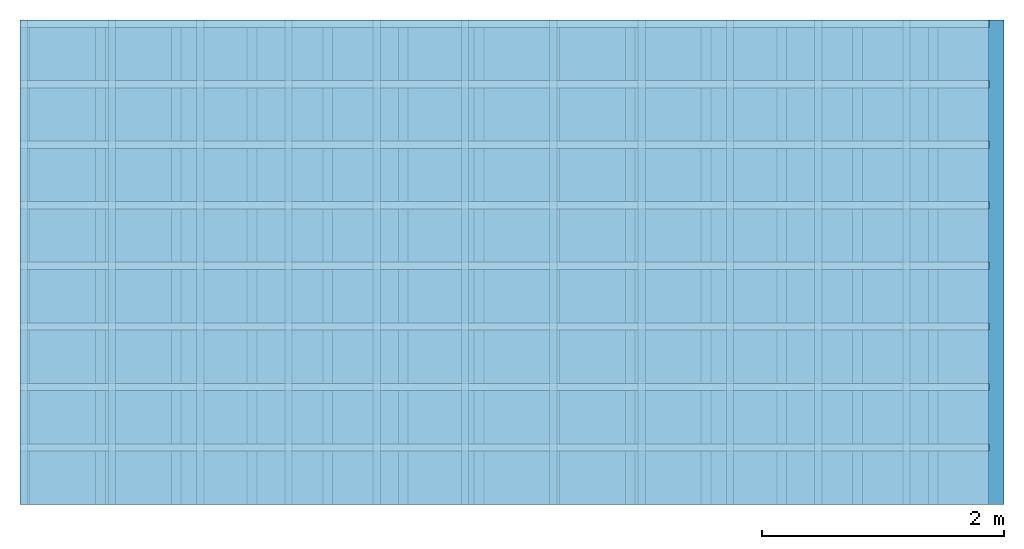
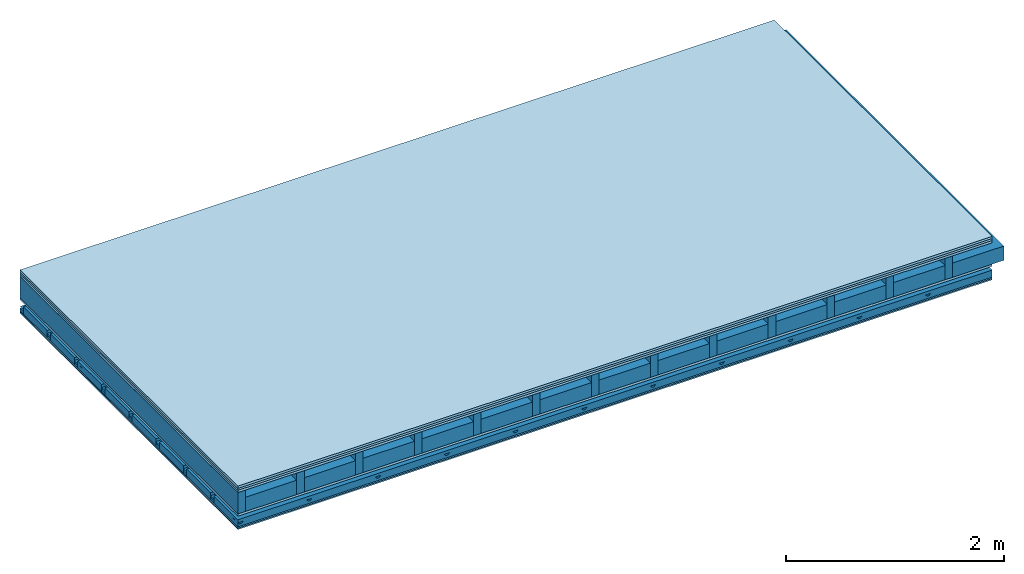
# One storey: 6 plates, 5 members, 1 element without a shape of its own.
"""IFC4 building model written with IfcOpenShell, lengths in metres."""

from ifc_helpers import new_model, si_unit, derived_unit, direction, frame, frame_2d, origin, origin_with_axes, place, context, project, spatial, polyline, rectangle, outline, extrude, material, layer, layer_set, type_object, element, aggregate, save


model = new_model("IFC4")

# Units and contexts
plan_context = context("Plan", 3, precision=1e-05, world=origin(), true_north=direction((0.0, 1.0)))
model_context = context("Model", 3, precision=1e-05, world=origin(), true_north=direction((0.0, 1.0)))
ifc_project = project(units=[si_unit("LENGTHUNIT", "METRE"), derived_unit("SOUNDPRESSUREUNIT", [(si_unit("PRESSUREUNIT", "PASCAL", prefix="MICRO"), 0)]), si_unit("ENERGYUNIT", "JOULE", prefix="MEGA"), si_unit("MASSUNIT", "GRAM", prefix="KILO"), derived_unit("THERMALTRANSMITTANCEUNIT", [(si_unit("POWERUNIT", "WATT"), 1), (si_unit("AREAUNIT", "SQUARE_METRE"), -1), (si_unit("THERMODYNAMICTEMPERATUREUNIT", "KELVIN"), -1)]), derived_unit("AREADENSITYUNIT", [(si_unit("MASSUNIT", "GRAM", prefix="KILO"), 1), (si_unit("AREAUNIT", "SQUARE_METRE"), -1)]), derived_unit("USERDEFINED", [(si_unit("ENERGYUNIT", "JOULE", prefix="MEGA"), 1), (si_unit("AREAUNIT", "SQUARE_METRE"), -1)])], contexts=[plan_context, model_context])

# Site, building, storey
site = spatial("IfcSite", under=ifc_project)
building_placement = place(None, origin())
building = spatial("IfcBuilding", under=site, at=building_placement)
storey_placement = place(building_placement, origin())
storey = spatial("IfcBuildingStorey", under=building, at=storey_placement)

# Slab, members, plates
ifc_material_1 = material(Name="Floor heating system Therm38 longitudinal", Category="03.007")
ifc_layer_1 = layer(ifc_material_1, 0.025, Name="On-material")
ifc_material_2 = material(Category="10.009")
ifc_layer_2 = layer(ifc_material_2, 0.022, Name="Impact sound insulation")
ifc_material_3 = material(Category="07.001")
ifc_layer_3 = layer(ifc_material_3, 0.025, Name="Sub-floor")
ifc_material_4 = material(Name="Rigid, of the art")
ifc_layer_4 = layer(ifc_material_4, 0.0, Name="Bond")
ifc_layer_5 = layer(None, 0.24, Name="Supporting structure")
ifc_layer_6 = layer(ifc_material_4, 0.0, Name="Bond")
ifc_layer_7 = layer(ifc_material_3, 0.025, Name="Lower layer 1")
ifc_layer_8 = layer(None, 0.093, Name="Coupling")
ifc_layer_9 = layer(None, 0.027, Name="Battens / profiles")
ifc_material_5 = material(Category="03.007")
ifc_layer_10 = layer(ifc_material_5, 0.015, Name="Ceiling covering 1st layer")
ifc_layer_11 = layer(ifc_material_5, 0.015, Name="Ceiling covering layer 2")
ifc_material_6 = material(Name="Glued joints")
ifc_layer_12 = layer(ifc_material_6, 0.0, Name="Surface / treatment")
ifc_layer_set = layer_set([ifc_layer_1, ifc_layer_2, ifc_layer_3, ifc_layer_4, ifc_layer_5, ifc_layer_6, ifc_layer_7, ifc_layer_8, ifc_layer_9, ifc_layer_10, ifc_layer_11, ifc_layer_12])
slab_type = type_object("IfcSlabType", Name="A0357", PredefinedType="NOTDEFINED", material=ifc_layer_set)
slab_placement = place(None, frame((0.0, 0.0, 0.0), z_axis=(0.0, 0.0, -1.0), x_axis=(1.0, 0.0, 0.0)))
slab = element("IfcSlab", 1, at=slab_placement, inside=storey, type_object=slab_type, material=ifc_layer_set, Name="Slab #1")
ifc_material_7 = material()
member_1_placement = place(slab_placement, origin())
member_1 = element("IfcMember", 2, at=member_1_placement, material=ifc_material_7, Name="Supporting structure", context=plan_context, shape_type="SweptSolid", body=[
    extrude(rectangle(XDim=0.08, YDim=0.24, at=frame_2d((0.04, 0.12), x_axis=(1.0, 0.0))), frame((0.0, 4.0, 0.072), z_axis=(0.0, -1.0, 0.0), x_axis=(1.0, 0.0, 0.0)), (0.0, 0.0, 1.0), 4.0),
    extrude(rectangle(XDim=0.08, YDim=0.24, at=frame_2d((0.04, 0.12), x_axis=(1.0, 0.0))), frame((0.625, 4.0, 0.072), z_axis=(0.0, -1.0, 0.0), x_axis=(1.0, 0.0, 0.0)), (0.0, 0.0, 1.0), 4.0),
    extrude(rectangle(XDim=0.08, YDim=0.24, at=frame_2d((0.04, 0.12), x_axis=(1.0, 0.0))), frame((1.25, 4.0, 0.072), z_axis=(0.0, -1.0, 0.0), x_axis=(1.0, 0.0, 0.0)), (0.0, 0.0, 1.0), 4.0),
    extrude(rectangle(XDim=0.08, YDim=0.24, at=frame_2d((0.04, 0.12), x_axis=(1.0, 0.0))), frame((1.875, 4.0, 0.072), z_axis=(0.0, -1.0, 0.0), x_axis=(1.0, 0.0, 0.0)), (0.0, 0.0, 1.0), 4.0),
    extrude(rectangle(XDim=0.08, YDim=0.24, at=frame_2d((0.04, 0.12), x_axis=(1.0, 0.0))), frame((2.5, 4.0, 0.072), z_axis=(0.0, -1.0, 0.0), x_axis=(1.0, 0.0, 0.0)), (0.0, 0.0, 1.0), 4.0),
    extrude(rectangle(XDim=0.08, YDim=0.24, at=frame_2d((0.04, 0.12), x_axis=(1.0, 0.0))), frame((3.125, 4.0, 0.072), z_axis=(0.0, -1.0, 0.0), x_axis=(1.0, 0.0, 0.0)), (0.0, 0.0, 1.0), 4.0),
    extrude(rectangle(XDim=0.08, YDim=0.24, at=frame_2d((0.04, 0.12), x_axis=(1.0, 0.0))), frame((3.75, 4.0, 0.072), z_axis=(0.0, -1.0, 0.0), x_axis=(1.0, 0.0, 0.0)), (0.0, 0.0, 1.0), 4.0),
    extrude(rectangle(XDim=0.08, YDim=0.24, at=frame_2d((0.04, 0.12), x_axis=(1.0, 0.0))), frame((4.375, 4.0, 0.072), z_axis=(0.0, -1.0, 0.0), x_axis=(1.0, 0.0, 0.0)), (0.0, 0.0, 1.0), 4.0),
    extrude(rectangle(XDim=0.08, YDim=0.24, at=frame_2d((0.04, 0.12), x_axis=(1.0, 0.0))), frame((5.0, 4.0, 0.072), z_axis=(0.0, -1.0, 0.0), x_axis=(1.0, 0.0, 0.0)), (0.0, 0.0, 1.0), 4.0),
    extrude(rectangle(XDim=0.08, YDim=0.24, at=frame_2d((0.04, 0.12), x_axis=(1.0, 0.0))), frame((5.625, 4.0, 0.072), z_axis=(0.0, -1.0, 0.0), x_axis=(1.0, 0.0, 0.0)), (0.0, 0.0, 1.0), 4.0),
    extrude(rectangle(XDim=0.08, YDim=0.24, at=frame_2d((0.04, 0.12), x_axis=(1.0, 0.0))), frame((6.25, 4.0, 0.072), z_axis=(0.0, -1.0, 0.0), x_axis=(1.0, 0.0, 0.0)), (0.0, 0.0, 1.0), 4.0),
    extrude(rectangle(XDim=0.08, YDim=0.24, at=frame_2d((0.04, 0.12), x_axis=(1.0, 0.0))), frame((6.875, 4.0, 0.072), z_axis=(0.0, -1.0, 0.0), x_axis=(1.0, 0.0, 0.0)), (0.0, 0.0, 1.0), 4.0),
    extrude(rectangle(XDim=0.08, YDim=0.24, at=frame_2d((0.04, 0.12), x_axis=(1.0, 0.0))), frame((7.5, 4.0, 0.072), z_axis=(0.0, -1.0, 0.0), x_axis=(1.0, 0.0, 0.0)), (0.0, 0.0, 1.0), 4.0),
])
ifc_material_8 = material()
member_2_placement = place(slab_placement, origin())
member_2 = element("IfcMember", 3, at=member_2_placement, material=ifc_material_8, Name="Cavity", context=plan_context, shape_type="SweptSolid", body=[
    extrude(rectangle(XDim=0.545, YDim=0.16, at=frame_2d((0.2725, 0.08), x_axis=(1.0, 0.0))), frame((0.08, 4.0, 0.152), z_axis=(0.0, -1.0, 0.0), x_axis=(1.0, 0.0, 0.0)), (0.0, 0.0, 1.0), 4.0),
    extrude(rectangle(XDim=0.545, YDim=0.16, at=frame_2d((0.2725, 0.08), x_axis=(1.0, 0.0))), frame((0.705, 4.0, 0.152), z_axis=(0.0, -1.0, 0.0), x_axis=(1.0, 0.0, 0.0)), (0.0, 0.0, 1.0), 4.0),
    extrude(rectangle(XDim=0.545, YDim=0.16, at=frame_2d((0.2725, 0.08), x_axis=(1.0, 0.0))), frame((1.33, 4.0, 0.152), z_axis=(0.0, -1.0, 0.0), x_axis=(1.0, 0.0, 0.0)), (0.0, 0.0, 1.0), 4.0),
    extrude(rectangle(XDim=0.545, YDim=0.16, at=frame_2d((0.2725, 0.08), x_axis=(1.0, 0.0))), frame((1.955, 4.0, 0.152), z_axis=(0.0, -1.0, 0.0), x_axis=(1.0, 0.0, 0.0)), (0.0, 0.0, 1.0), 4.0),
    extrude(rectangle(XDim=0.545, YDim=0.16, at=frame_2d((0.2725, 0.08), x_axis=(1.0, 0.0))), frame((2.58, 4.0, 0.152), z_axis=(0.0, -1.0, 0.0), x_axis=(1.0, 0.0, 0.0)), (0.0, 0.0, 1.0), 4.0),
    extrude(rectangle(XDim=0.545, YDim=0.16, at=frame_2d((0.2725, 0.08), x_axis=(1.0, 0.0))), frame((3.205, 4.0, 0.152), z_axis=(0.0, -1.0, 0.0), x_axis=(1.0, 0.0, 0.0)), (0.0, 0.0, 1.0), 4.0),
    extrude(rectangle(XDim=0.545, YDim=0.16, at=frame_2d((0.2725, 0.08), x_axis=(1.0, 0.0))), frame((3.83, 4.0, 0.152), z_axis=(0.0, -1.0, 0.0), x_axis=(1.0, 0.0, 0.0)), (0.0, 0.0, 1.0), 4.0),
    extrude(rectangle(XDim=0.545, YDim=0.16, at=frame_2d((0.2725, 0.08), x_axis=(1.0, 0.0))), frame((4.455, 4.0, 0.152), z_axis=(0.0, -1.0, 0.0), x_axis=(1.0, 0.0, 0.0)), (0.0, 0.0, 1.0), 4.0),
    extrude(rectangle(XDim=0.545, YDim=0.16, at=frame_2d((0.2725, 0.08), x_axis=(1.0, 0.0))), frame((5.08, 4.0, 0.152), z_axis=(0.0, -1.0, 0.0), x_axis=(1.0, 0.0, 0.0)), (0.0, 0.0, 1.0), 4.0),
    extrude(rectangle(XDim=0.545, YDim=0.16, at=frame_2d((0.2725, 0.08), x_axis=(1.0, 0.0))), frame((5.705, 4.0, 0.152), z_axis=(0.0, -1.0, 0.0), x_axis=(1.0, 0.0, 0.0)), (0.0, 0.0, 1.0), 4.0),
    extrude(rectangle(XDim=0.545, YDim=0.16, at=frame_2d((0.2725, 0.08), x_axis=(1.0, 0.0))), frame((6.33, 4.0, 0.152), z_axis=(0.0, -1.0, 0.0), x_axis=(1.0, 0.0, 0.0)), (0.0, 0.0, 1.0), 4.0),
    extrude(rectangle(XDim=0.545, YDim=0.16, at=frame_2d((0.2725, 0.08), x_axis=(1.0, 0.0))), frame((6.955, 4.0, 0.152), z_axis=(0.0, -1.0, 0.0), x_axis=(1.0, 0.0, 0.0)), (0.0, 0.0, 1.0), 4.0),
    extrude(rectangle(XDim=0.545, YDim=0.16, at=frame_2d((0.2725, 0.08), x_axis=(1.0, 0.0))), frame((7.58, 4.0, 0.152), z_axis=(0.0, -1.0, 0.0), x_axis=(1.0, 0.0, 0.0)), (0.0, 0.0, 1.0), 4.0),
])
ifc_material_9 = material()
member_3_placement = place(slab_placement, origin())
member_3 = element("IfcMember", 4, at=member_3_placement, material=ifc_material_9, Name="Coupling", context=plan_context, shape_type="SweptSolid", body=[
    extrude(outline(polyline([(0.0, 0.0), (0.06, 0.0), (0.04, 0.02), (0.02, 0.02), (0.0, 0.0)])), frame((0.0, 4.0, 0.41), z_axis=(0.0, -1.0, 0.0), x_axis=(1.0, 0.0, 0.0)), (0.0, 0.0, 1.0), 4.0),
    extrude(outline(polyline([(0.0, 0.0), (0.06, 0.0), (0.04, 0.02), (0.02, 0.02), (0.0, 0.0)])), frame((0.729, 4.0, 0.41), z_axis=(0.0, -1.0, 0.0), x_axis=(1.0, 0.0, 0.0)), (0.0, 0.0, 1.0), 4.0),
    extrude(outline(polyline([(0.0, 0.0), (0.06, 0.0), (0.04, 0.02), (0.02, 0.02), (0.0, 0.0)])), frame((1.458, 4.0, 0.41), z_axis=(0.0, -1.0, 0.0), x_axis=(1.0, 0.0, 0.0)), (0.0, 0.0, 1.0), 4.0),
    extrude(outline(polyline([(0.0, 0.0), (0.06, 0.0), (0.04, 0.02), (0.02, 0.02), (0.0, 0.0)])), frame((2.187, 4.0, 0.41), z_axis=(0.0, -1.0, 0.0), x_axis=(1.0, 0.0, 0.0)), (0.0, 0.0, 1.0), 4.0),
    extrude(outline(polyline([(0.0, 0.0), (0.06, 0.0), (0.04, 0.02), (0.02, 0.02), (0.0, 0.0)])), frame((2.916, 4.0, 0.41), z_axis=(0.0, -1.0, 0.0), x_axis=(1.0, 0.0, 0.0)), (0.0, 0.0, 1.0), 4.0),
    extrude(outline(polyline([(0.0, 0.0), (0.06, 0.0), (0.04, 0.02), (0.02, 0.02), (0.0, 0.0)])), frame((3.645, 4.0, 0.41), z_axis=(0.0, -1.0, 0.0), x_axis=(1.0, 0.0, 0.0)), (0.0, 0.0, 1.0), 4.0),
    extrude(outline(polyline([(0.0, 0.0), (0.06, 0.0), (0.04, 0.02), (0.02, 0.02), (0.0, 0.0)])), frame((4.374, 4.0, 0.41), z_axis=(0.0, -1.0, 0.0), x_axis=(1.0, 0.0, 0.0)), (0.0, 0.0, 1.0), 4.0),
    extrude(outline(polyline([(0.0, 0.0), (0.06, 0.0), (0.04, 0.02), (0.02, 0.02), (0.0, 0.0)])), frame((5.103, 4.0, 0.41), z_axis=(0.0, -1.0, 0.0), x_axis=(1.0, 0.0, 0.0)), (0.0, 0.0, 1.0), 4.0),
    extrude(outline(polyline([(0.0, 0.0), (0.06, 0.0), (0.04, 0.02), (0.02, 0.02), (0.0, 0.0)])), frame((5.832, 4.0, 0.41), z_axis=(0.0, -1.0, 0.0), x_axis=(1.0, 0.0, 0.0)), (0.0, 0.0, 1.0), 4.0),
    extrude(outline(polyline([(0.0, 0.0), (0.06, 0.0), (0.04, 0.02), (0.02, 0.02), (0.0, 0.0)])), frame((6.561, 4.0, 0.41), z_axis=(0.0, -1.0, 0.0), x_axis=(1.0, 0.0, 0.0)), (0.0, 0.0, 1.0), 4.0),
    extrude(outline(polyline([(0.0, 0.0), (0.06, 0.0), (0.04, 0.02), (0.02, 0.02), (0.0, 0.0)])), frame((7.29, 4.0, 0.41), z_axis=(0.0, -1.0, 0.0), x_axis=(1.0, 0.0, 0.0)), (0.0, 0.0, 1.0), 4.0),
])
ifc_material_10 = material()
member_4_placement = place(slab_placement, origin())
member_4 = element("IfcMember", 5, at=member_4_placement, material=ifc_material_10, Name="Battens / profiles", context=plan_context, shape_type="SweptSolid", body=[
    extrude(rectangle(XDim=0.06, YDim=0.027, at=frame_2d((0.03, 0.0135), x_axis=(1.0, 0.0))), frame((0.0, 0.0, 0.43), z_axis=(1.0, 0.0, 0.0), x_axis=(0.0, 1.0, 0.0)), (0.0, 0.0, 1.0), 8.0),
    extrude(rectangle(XDim=0.06, YDim=0.027, at=frame_2d((0.03, 0.0135), x_axis=(1.0, 0.0))), frame((0.0, 0.5, 0.43), z_axis=(1.0, 0.0, 0.0), x_axis=(0.0, 1.0, 0.0)), (0.0, 0.0, 1.0), 8.0),
    extrude(rectangle(XDim=0.06, YDim=0.027, at=frame_2d((0.03, 0.0135), x_axis=(1.0, 0.0))), frame((0.0, 1.0, 0.43), z_axis=(1.0, 0.0, 0.0), x_axis=(0.0, 1.0, 0.0)), (0.0, 0.0, 1.0), 8.0),
    extrude(rectangle(XDim=0.06, YDim=0.027, at=frame_2d((0.03, 0.0135), x_axis=(1.0, 0.0))), frame((0.0, 1.5, 0.43), z_axis=(1.0, 0.0, 0.0), x_axis=(0.0, 1.0, 0.0)), (0.0, 0.0, 1.0), 8.0),
    extrude(rectangle(XDim=0.06, YDim=0.027, at=frame_2d((0.03, 0.0135), x_axis=(1.0, 0.0))), frame((0.0, 2.0, 0.43), z_axis=(1.0, 0.0, 0.0), x_axis=(0.0, 1.0, 0.0)), (0.0, 0.0, 1.0), 8.0),
    extrude(rectangle(XDim=0.06, YDim=0.027, at=frame_2d((0.03, 0.0135), x_axis=(1.0, 0.0))), frame((0.0, 2.5, 0.43), z_axis=(1.0, 0.0, 0.0), x_axis=(0.0, 1.0, 0.0)), (0.0, 0.0, 1.0), 8.0),
    extrude(rectangle(XDim=0.06, YDim=0.027, at=frame_2d((0.03, 0.0135), x_axis=(1.0, 0.0))), frame((0.0, 3.0, 0.43), z_axis=(1.0, 0.0, 0.0), x_axis=(0.0, 1.0, 0.0)), (0.0, 0.0, 1.0), 8.0),
    extrude(rectangle(XDim=0.06, YDim=0.027, at=frame_2d((0.03, 0.0135), x_axis=(1.0, 0.0))), frame((0.0, 3.5, 0.43), z_axis=(1.0, 0.0, 0.0), x_axis=(0.0, 1.0, 0.0)), (0.0, 0.0, 1.0), 8.0),
])
member_5_placement = place(slab_placement, origin())
member_5 = element("IfcMember", 6, at=member_5_placement, material=ifc_material_8, Name="Cavity", context=plan_context, shape_type="SweptSolid", body=[
    extrude(rectangle(XDim=0.44, YDim=0.08, at=frame_2d((0.22, 0.04), x_axis=(1.0, 0.0))), frame((0.0, 0.06, 0.377), z_axis=(1.0, 0.0, 0.0), x_axis=(0.0, 1.0, 0.0)), (0.0, 0.0, 1.0), 8.0),
    extrude(rectangle(XDim=0.44, YDim=0.08, at=frame_2d((0.22, 0.04), x_axis=(1.0, 0.0))), frame((0.0, 0.56, 0.377), z_axis=(1.0, 0.0, 0.0), x_axis=(0.0, 1.0, 0.0)), (0.0, 0.0, 1.0), 8.0),
    extrude(rectangle(XDim=0.44, YDim=0.08, at=frame_2d((0.22, 0.04), x_axis=(1.0, 0.0))), frame((0.0, 1.06, 0.377), z_axis=(1.0, 0.0, 0.0), x_axis=(0.0, 1.0, 0.0)), (0.0, 0.0, 1.0), 8.0),
    extrude(rectangle(XDim=0.44, YDim=0.08, at=frame_2d((0.22, 0.04), x_axis=(1.0, 0.0))), frame((0.0, 1.56, 0.377), z_axis=(1.0, 0.0, 0.0), x_axis=(0.0, 1.0, 0.0)), (0.0, 0.0, 1.0), 8.0),
    extrude(rectangle(XDim=0.44, YDim=0.08, at=frame_2d((0.22, 0.04), x_axis=(1.0, 0.0))), frame((0.0, 2.06, 0.377), z_axis=(1.0, 0.0, 0.0), x_axis=(0.0, 1.0, 0.0)), (0.0, 0.0, 1.0), 8.0),
    extrude(rectangle(XDim=0.44, YDim=0.08, at=frame_2d((0.22, 0.04), x_axis=(1.0, 0.0))), frame((0.0, 2.56, 0.377), z_axis=(1.0, 0.0, 0.0), x_axis=(0.0, 1.0, 0.0)), (0.0, 0.0, 1.0), 8.0),
    extrude(rectangle(XDim=0.44, YDim=0.08, at=frame_2d((0.22, 0.04), x_axis=(1.0, 0.0))), frame((0.0, 3.06, 0.377), z_axis=(1.0, 0.0, 0.0), x_axis=(0.0, 1.0, 0.0)), (0.0, 0.0, 1.0), 8.0),
    extrude(rectangle(XDim=0.44, YDim=0.08, at=frame_2d((0.22, 0.04), x_axis=(1.0, 0.0))), frame((0.0, 3.56, 0.377), z_axis=(1.0, 0.0, 0.0), x_axis=(0.0, 1.0, 0.0)), (0.0, 0.0, 1.0), 8.0),
])
plate_1_placement = place(slab_placement, origin())
plate_1 = element("IfcPlate", 7, at=plate_1_placement, material=ifc_material_1, Name="On-material", context=plan_context, shape_type="SweptSolid", body=[
    extrude(rectangle(XDim=8.0, YDim=4.0, at=frame_2d((4.0, 2.0), x_axis=(1.0, 0.0))), origin_with_axes(), (0.0, 0.0, 1.0), 0.025),
])
plate_2_placement = place(slab_placement, origin())
plate_2 = element("IfcPlate", 8, at=plate_2_placement, material=ifc_material_2, Name="Impact sound insulation", context=plan_context, shape_type="SweptSolid", body=[
    extrude(rectangle(XDim=8.0, YDim=4.0, at=frame_2d((4.0, 2.0), x_axis=(1.0, 0.0))), frame((0.0, 0.0, 0.025), z_axis=(0.0, 0.0, 1.0), x_axis=(1.0, 0.0, 0.0)), (0.0, 0.0, 1.0), 0.022),
])
plate_3_placement = place(slab_placement, origin())
plate_3 = element("IfcPlate", 9, at=plate_3_placement, material=ifc_material_3, Name="Sub-floor", context=plan_context, shape_type="SweptSolid", body=[
    extrude(rectangle(XDim=8.0, YDim=4.0, at=frame_2d((4.0, 2.0), x_axis=(1.0, 0.0))), frame((0.0, 0.0, 0.047), z_axis=(0.0, 0.0, 1.0), x_axis=(1.0, 0.0, 0.0)), (0.0, 0.0, 1.0), 0.025),
])
plate_4_placement = place(slab_placement, origin())
plate_4 = element("IfcPlate", 10, at=plate_4_placement, material=ifc_material_3, Name="Lower layer 1", context=plan_context, shape_type="SweptSolid", body=[
    extrude(rectangle(XDim=8.0, YDim=4.0, at=frame_2d((4.0, 2.0), x_axis=(1.0, 0.0))), frame((0.0, 0.0, 0.312), z_axis=(0.0, 0.0, 1.0), x_axis=(1.0, 0.0, 0.0)), (0.0, 0.0, 1.0), 0.025),
])
plate_5_placement = place(slab_placement, origin())
plate_5 = element("IfcPlate", 11, at=plate_5_placement, material=ifc_material_5, Name="Ceiling covering 1st layer", context=plan_context, shape_type="SweptSolid", body=[
    extrude(rectangle(XDim=8.0, YDim=4.0, at=frame_2d((4.0, 2.0), x_axis=(1.0, 0.0))), frame((0.0, 0.0, 0.457), z_axis=(0.0, 0.0, 1.0), x_axis=(1.0, 0.0, 0.0)), (0.0, 0.0, 1.0), 0.015),
])
plate_6_placement = place(slab_placement, origin())
plate_6 = element("IfcPlate", 12, at=plate_6_placement, material=ifc_material_5, Name="Ceiling covering layer 2", context=plan_context, shape_type="SweptSolid", body=[
    extrude(rectangle(XDim=8.0, YDim=4.0, at=frame_2d((4.0, 2.0), x_axis=(1.0, 0.0))), frame((0.0, 0.0, 0.472), z_axis=(0.0, 0.0, 1.0), x_axis=(1.0, 0.0, 0.0)), (0.0, 0.0, 1.0), 0.015),
])
aggregate(slab, [plate_1, plate_2, plate_3, member_1, member_2, plate_4, member_3, member_4, member_5, plate_5, plate_6])

save(model, "model.ifc")
